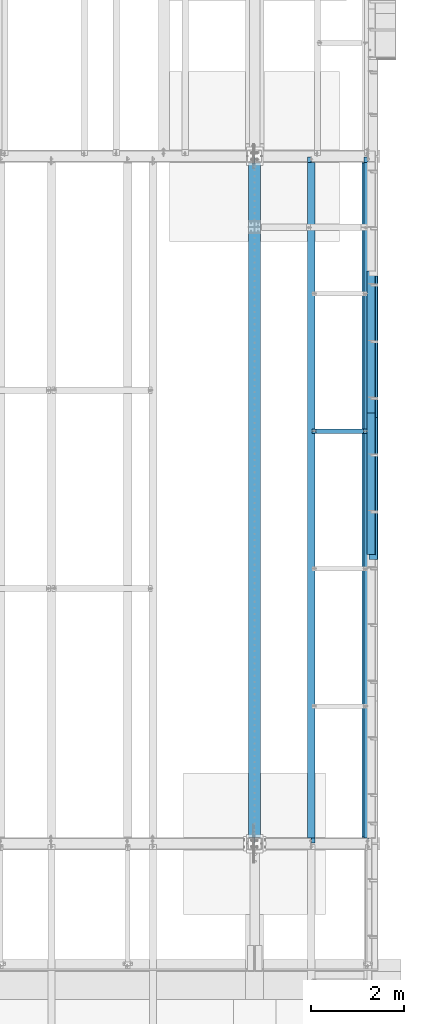
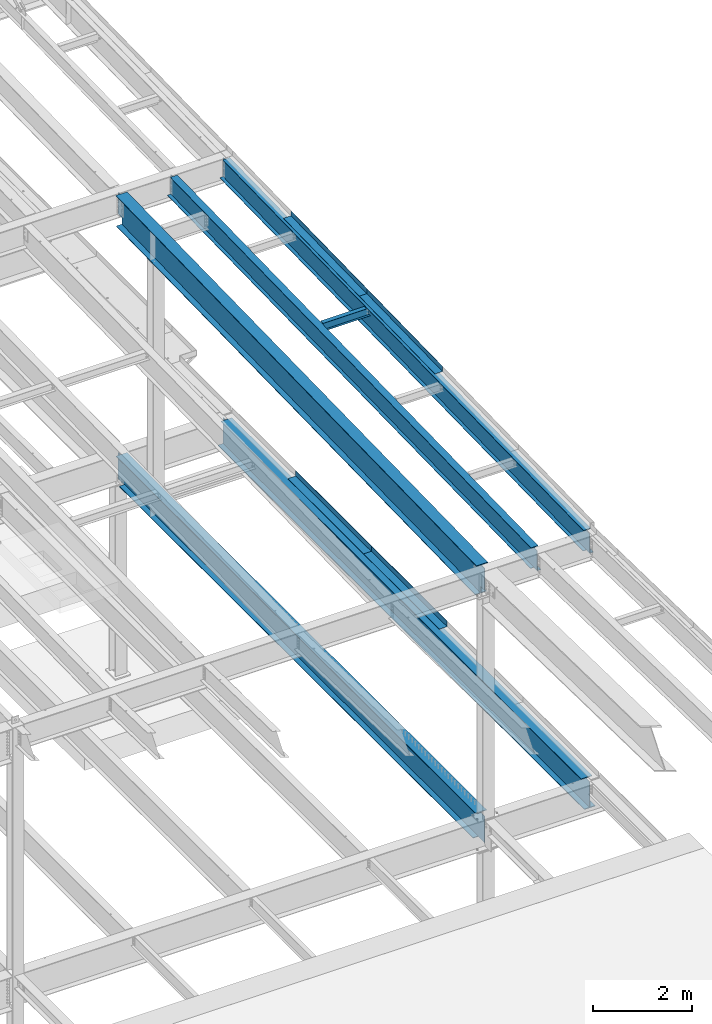
# One storey, part 1122 of 1763: 10 beams, 6 elements without a shape of their own.
"""IFC2X3 building model written with IfcOpenShell, lengths in millimetres."""

from ifc_helpers import new_model, si_unit, frame, origin_with_axes, place, context, subcontext, project, spatial, faceted_brep, material, type_object, element, aggregate, save


model = new_model("IFC2X3")

# Units and contexts
model_context = context("Model", 3, precision=1e-05, world=origin_with_axes())
body_context = subcontext(model_context, "Body", "Model", "MODEL_VIEW")
ifc_project = project(units=[si_unit("LENGTHUNIT", "METRE", prefix="MILLI"), si_unit("AREAUNIT", "SQUARE_METRE"), si_unit("VOLUMEUNIT", "CUBIC_METRE"), si_unit("MASSUNIT", "GRAM", prefix="KILO"), si_unit("TIMEUNIT", "SECOND"), si_unit("PLANEANGLEUNIT", "RADIAN"), si_unit("SOLIDANGLEUNIT", "STERADIAN"), si_unit("THERMODYNAMICTEMPERATUREUNIT", "DEGREE_CELSIUS"), si_unit("LUMINOUSINTENSITYUNIT", "LUMEN")], contexts=[model_context])

# Site, building, storey
site_placement = place(None, origin_with_axes())
site = spatial("IfcSite", under=ifc_project, at=site_placement, CompositionType="ELEMENT")
building_placement = place(site_placement, origin_with_axes())
building = spatial("IfcBuilding", under=site, at=building_placement, Name="Undefined", CompositionType="ELEMENT")
storey_placement = place(building_placement, origin_with_axes())
storey = spatial("IfcBuildingStorey", under=building, at=storey_placement, Name="Undefined", CompositionType="ELEMENT", Elevation=0.0)

# Assembly, beam
assembly_1_placement = place(storey_placement, origin_with_axes())
assembly_1 = element("IfcElementAssembly", 1, at=assembly_1_placement, inside=storey, Name="BEAM", AssemblyPlace="NOTDEFINED", PredefinedType="RIGID_FRAME")
ifc_material_1 = material(Name="STEEL/A992")
beam_type_1 = type_object("IfcBeamType", Name="W8X10", PredefinedType="NOTDEFINED")
beam_1_placement = place(assembly_1_placement, frame((-22808.6484080275, 38892.48, 11373.7981173788), z_axis=(0.0, 0.0, 1.0), x_axis=(1.0, 0.0, 0.0)))
beam_1 = element("IfcBeam", 2, at=beam_1_placement, type_object=beam_type_1, material=ifc_material_1, Name="BEAM", ObjectType="W8X10", context=body_context, shape_type="Brep", body=[
    faceted_brep([(1119.19526367187, -50.7999999999993, 100.012500000001), (1119.19526367187, -50.7999999999993, 95.25), (1119.19526367187, -2.38124999999854, 95.25), (1119.19526367187, -2.38124999999854, 83.877501483119), (1119.19526367187, 2.38124999999854, 83.877501483119), (1119.19526367187, 2.38124999999854, 95.25), (1119.19526367187, 50.7999999999993, 95.25), (1119.19526367187, 50.7999999999993, 100.012500000001), (1120.16199359446, -2.38124999999854, 79.0174219650726), (1120.16199359446, 2.38124999999854, 79.0174219650726), (1122.91500749494, -2.38124999999854, 74.8972454969189), (1122.91500749494, 2.38124999999854, 74.8972454969189), (1127.03518396309, -2.38124999999854, 72.1442315964414), (1127.03518396309, 2.38124999999854, 72.1442315964414), (1131.89526348114, -2.38124999999854, 71.1775016738538), (1131.89526348114, 2.38124999999854, 71.1775016738538), (1201.74526367187, -2.38124999999854, 71.1775016738538), (1201.74526367187, 2.38124999999854, 71.1775016738538), (100.012500000012, -50.7999999999993, 100.012500000001), (100.012500000012, 50.7999999999993, 100.012500000001), (100.012500000012, 50.7999999999993, 95.25), (100.012500000012, 2.38124999999854, 95.25), (100.012500000012, 2.38124999999854, 83.877501483119), (100.012500000012, -2.38124999999854, 83.877501483119), (100.012500000012, -2.38124999999854, 95.25), (100.012500000012, -50.7999999999993, 95.25), (99.0457700774241, 2.38124999999854, 79.0174219650726), (99.0457700774241, -2.38124999999854, 79.0174219650726), (96.2927561769466, 2.38124999999854, 74.8972454969189), (96.2927561769466, -2.38124999999854, 74.8972454969189), (92.1725797087929, 2.38124999999854, 72.1442315964414), (92.1725797087929, -2.38124999999854, 72.1442315964414), (87.3125001907465, 2.38124999999854, 71.1775016738538), (87.3125001907465, -2.38124999999854, 71.1775016738538), (17.4625000000015, 2.38124999999854, 71.1775016738538), (17.4625000000015, -2.38124999999854, 71.1775016738538), (17.462499935149, 2.38124999999854, -95.25), (17.4625000000015, 50.7999999999993, -95.25), (17.4625000000015, 50.7999999999993, -100.012500000001), (17.4624996160601, -50.8000000000029, -100.012500000001), (17.4624996160601, -50.8000000000029, -95.25), (17.4624999065727, -2.38124999999854, -95.25), (1201.74526367187, 2.38124999999854, -95.25), (1201.74526367187, 50.7999999999993, -95.25), (1201.74526367187, 50.7999999999993, -100.012500000001), (1201.74526367187, -50.7999999999993, -100.012500000001), (1201.74526367187, -50.7999999999993, -95.25), (1201.74526367187, -2.38124999999854, -95.25)], [[[0, 1, 2, 3, 4, 5, 6, 7]], [[8, 9, 4, 3]], [[10, 11, 9, 8]], [[12, 13, 11, 10]], [[14, 15, 13, 12]], [[16, 17, 15, 14]], [[18, 19, 20, 21, 22, 23, 24, 25]], [[23, 22, 26, 27]], [[27, 26, 28, 29]], [[29, 28, 30, 31]], [[31, 30, 32, 33]], [[33, 32, 34, 35]], [[36, 37, 38, 39, 40, 41, 35, 34]], [[37, 36, 42, 43]], [[38, 37, 43, 44]], [[39, 38, 44, 45]], [[40, 39, 45, 46]], [[41, 40, 46, 47]], [[12, 10, 8, 3, 2, 24, 23, 27, 29, 31, 33, 35, 41, 47, 16, 14]], [[25, 24, 2, 1]], [[18, 25, 1, 0]], [[19, 18, 0, 7]], [[20, 19, 7, 6]], [[21, 20, 6, 5]], [[42, 36, 34, 32, 30, 28, 26, 22, 21, 5, 4, 9, 11, 13, 15, 17]], [[47, 46, 45, 44, 43, 42, 17, 16]]]),
])
aggregate(assembly_1, [beam_1])

# Assembly, beams
assembly_2_placement = place(storey_placement, origin_with_axes())
assembly_2 = element("IfcElementAssembly", 3, at=assembly_2_placement, inside=storey, Name="BEAM", AssemblyPlace="NOTDEFINED", PredefinedType="RIGID_FRAME")
ifc_material_2 = material(Name="STEEL/A36")
beam_type_2 = type_object("IfcBeamType", PredefinedType="NOTDEFINED")
beam_2_placement = place(assembly_2_placement, frame((-21564.0372736984, 40709.85, 5199.0625), z_axis=(0.0, -1.0, 0.0), x_axis=(1.0, 0.0, 0.0)))
beam_2 = element("IfcBeam", 4, at=beam_2_placement, type_object=beam_type_2, material=ifc_material_2, Name="BENT_PLATE", context=body_context, shape_type="Brep", body=[
    faceted_brep([(0.0, -4.76249999999982, -1524.0), (0.0, -4.76249999999982, 1524.0), (0.0, 4.76249999999982, 1524.0), (0.0, 4.76249999999982, -1524.0), (177.799996948241, 4.76249999999982, 1524.0), (177.799996948241, 4.76249999999982, -1524.0), (187.324996948242, -4.76249999999982, -1524.0), (187.324996948242, -4.76249999999982, 1524.0), (177.799996948241, 134.937496948242, 1524.0), (177.799996948241, 134.937496948242, -1524.0), (187.324996948242, 134.937496948242, 1524.0), (187.324996948242, 134.937496948242, -1524.0)], [[[0, 1, 2, 3]], [[3, 2, 4, 5]], [[1, 0, 6, 7]], [[5, 4, 8, 9]], [[4, 2, 1, 7, 10, 8]], [[7, 6, 11, 10]], [[6, 0, 3, 5, 9, 11]], [[10, 11, 9, 8]]]),
])
beam_3_placement = place(assembly_2_placement, frame((-21564.0372736984, 37661.85, 5199.0625), z_axis=(0.0, -1.0, 0.0), x_axis=(1.0, 0.0, 0.0)))
beam_3 = element("IfcBeam", 5, at=beam_3_placement, type_object=beam_type_2, material=ifc_material_2, Name="BENT_PLATE", context=body_context, shape_type="Brep", body=[
    faceted_brep([(0.0, -4.76249999999982, -1524.0), (0.0, -4.76249999999982, 1524.0), (0.0, 4.76249999999982, 1524.0), (0.0, 4.76249999999982, -1524.0), (177.799996948241, 4.76249999999982, 1524.0), (177.799996948241, 4.76249999999982, -1524.0), (187.324996948242, -4.76249999999982, -1524.0), (187.324996948242, -4.76249999999982, 1524.0), (177.799996948241, 134.937496948242, 1524.0), (177.799996948241, 134.937496948242, -1524.0), (187.324996948242, 134.937496948242, 1524.0), (187.324996948242, 134.937496948242, -1524.0)], [[[0, 1, 2, 3]], [[3, 2, 4, 5]], [[1, 0, 6, 7]], [[5, 4, 8, 9]], [[4, 2, 1, 7, 10, 8]], [[7, 6, 11, 10]], [[6, 0, 3, 5, 9, 11]], [[10, 11, 9, 8]]]),
])

assembly_3_placement = place(storey_placement, origin_with_axes())
assembly_3 = element("IfcElementAssembly", 6, at=assembly_3_placement, inside=storey, Name="BEAM", AssemblyPlace="NOTDEFINED", PredefinedType="RIGID_FRAME")
beam_type_3 = type_object("IfcBeamType", PredefinedType="NOTDEFINED")
beam_4_placement = place(assembly_3_placement, frame((-21608.4906443556, 40810.1470958945, 11516.6621670875), z_axis=(0.0, -0.999786037781472, -0.0206852279954809), x_axis=(1.0, 0.0, 0.0)))
beam_4 = element("IfcBeam", 7, at=beam_4_placement, type_object=beam_type_3, material=ifc_material_2, Name="BENT_PLATE", context=body_context, shape_type="Brep", body=[
    faceted_brep([(0.0, -3.17499999999927, -1523.99999999999), (0.0, -3.17499999999927, 1524.0), (0.0, 3.17499999999927, 1524.0), (0.0, 3.17499999999927, -1523.99999999999), (174.625006103754, 3.17500000029031, 1523.99999999885), (174.625006103754, 3.17499999971005, -1523.99999999885), (180.975006103752, -3.17500000028485, -1523.99999999885), (180.975006103752, -3.17499999970642, 1523.99999999885), (174.625006103754, 123.824997298747, 1523.99999999882), (174.625006103754, 123.824997298168, -1523.99999999888), (180.975006103752, 123.824997298747, 1523.99999999882), (180.975006103752, 123.824997298168, -1523.99999999888)], [[[0, 1, 2, 3]], [[3, 2, 4, 5]], [[1, 0, 6, 7]], [[5, 4, 8, 9]], [[4, 2, 1, 7, 10, 8]], [[7, 6, 11, 10]], [[6, 0, 3, 5, 9, 11]], [[10, 11, 9, 8]]]),
])
beam_5_placement = place(assembly_3_placement, frame((-21608.4906443556, 37762.7992527388, 11453.6135921579), z_axis=(0.0, -0.999786037781472, -0.0206852279954809), x_axis=(1.0, 0.0, 0.0)))
beam_5 = element("IfcBeam", 8, at=beam_5_placement, type_object=beam_type_3, material=ifc_material_2, Name="BENT_PLATE", context=body_context, shape_type="Brep", body=[
    faceted_brep([(0.0, -3.17499999999927, -1523.99999999999), (0.0, -3.17499999999927, 1524.0), (0.0, 3.17499999999927, 1524.0), (0.0, 3.17499999999927, -1523.99999999999), (174.625006103754, 3.17500000029031, 1523.99999999885), (174.625006103754, 3.17499999971005, -1523.99999999885), (180.975006103752, -3.17500000028485, -1523.99999999885), (180.975006103752, -3.17499999970642, 1523.99999999885), (174.625006103754, 123.824997298747, 1523.99999999882), (174.625006103754, 123.824997298168, -1523.99999999888), (180.975006103752, 123.824997298747, 1523.99999999882), (180.975006103752, 123.824997298168, -1523.99999999888)], [[[0, 1, 2, 3]], [[3, 2, 4, 5]], [[1, 0, 6, 7]], [[5, 4, 8, 9]], [[4, 2, 1, 7, 10, 8]], [[7, 6, 11, 10]], [[6, 0, 3, 5, 9, 11]], [[10, 11, 9, 8]]]),
])

# Assembly, beam
assembly_4_placement = place(storey_placement, origin_with_axes())
assembly_4 = element("IfcElementAssembly", 9, at=assembly_4_placement, inside=storey, Name="BEAM", AssemblyPlace="NOTDEFINED", PredefinedType="RIGID_FRAME")
beam_type_4 = type_object("IfcBeamType", Name="W30X90", PredefinedType="NOTDEFINED")
beam_6_placement = place(assembly_4_placement, frame((-24027.8372736984, 30030.5497207982, 10915.7301609411), z_axis=(0.0, -0.0206852279954837, 0.999786037781472), x_axis=(0.0, 0.999786037781472, 0.0206852279954825)))
beam_6 = element("IfcBeam", 10, at=beam_6_placement, type_object=beam_type_4, material=ifc_material_1, Name="BEAM", ObjectType="W30X90", context=body_context, shape_type="Brep", body=[
    faceted_brep([(14640.7034803743, 131.762500000001, 358.774999996942), (14640.7034803743, 6.34999999999854, 358.774999996942), (129.757398656984, 6.34999999999854, 358.774999999707), (129.757398656984, 131.762500000001, 358.774999999707), (117.057398847737, -6.34999999999854, 330.199999999233), (117.057398847737, 6.34999999999854, 330.199999999233), (99.9081682041979, 6.34999999999854, 330.199999999239), (17.3405018432495, 6.34999999999854, 330.199999999255), (17.3405018432495, -6.34999999999854, 330.199999999255), (121.917478365773, -6.34999999999854, 331.166729921819), (121.917478365773, 6.34999999999854, 331.166729921819), (126.037654833919, -6.34999999999854, 333.919743822291), (126.037654833919, 6.34999999999854, 333.919743822291), (128.790668734389, -6.34999999999854, 338.039920290434), (128.790668734389, 6.34999999999854, 338.039920290434), (129.757398656981, -6.34999999999854, 342.899999808467), (129.757398656981, 6.34999999999854, 342.899999808467), (14640.7034803743, -131.762500000001, 374.649999996929), (14640.7034803743, 131.762500000001, 374.649999996929), (129.757398656984, 131.762500000001, 374.649999999694), (129.757398656984, -131.762500000001, 374.649999999694), (14640.7034803743, -131.762500000001, 358.774999996942), (129.757398656984, -131.762500000001, 358.774999999707), (14640.7034803743, -6.34999999999854, 358.774999996942), (129.757398656984, -6.34999999999854, 358.774999999707), (14640.7034803743, -6.34999999999854, 342.899999791671), (14640.7034803743, 6.34999999999854, 342.899999791671), (14641.6702102968, -6.34999999999854, 338.039920273635), (14641.6702102968, 6.34999999999854, 338.039920273635), (14644.4232241973, -6.34999999999854, 333.919743805487), (14644.4232241973, 6.34999999999854, 333.919743805487), (14648.5434006655, -6.34999999999854, 331.166729905017), (14648.5434006655, 6.34999999999854, 331.166729905017), (14653.4034801835, -6.34999999999854, 330.199999982429), (14653.4034801835, 6.34999999999854, 330.199999982429), (14766.7838252642, -6.34999999999854, 330.199999982409), (14766.7838252642, 6.34999999999854, 330.199999982409), (14755.879342702, -6.34999999999854, -196.850000016262), (14755.879342702, 6.34999999999854, -196.850000016262), (14615.303480183, -6.34999999999854, -196.850000016202), (14615.303480183, 6.34999999999854, -196.850000016202), (14610.4434006649, -6.34999999999854, -197.816729938788), (14610.4434006649, 6.34999999999854, -197.816729938788), (14606.3232241968, -6.34999999999854, -200.569743839258), (14606.3232241968, 6.34999999999854, -200.569743839258), (14603.5702102963, -6.34999999999854, -204.689920307403), (14603.5702102963, 6.34999999999854, -204.689920307403), (14602.6034803737, -6.34999999999854, -209.549999825436), (14602.6034803737, 6.34999999999854, -209.549999825436), (14602.6034803737, -6.34999999999854, -358.77500000251), (14602.6034803737, -131.762500000001, -358.77500000251), (14602.6034803736, -131.762500000001, -374.650000002497), (14602.6034803736, 131.762500000001, -374.650000002497), (14602.6034803737, 131.762500000001, -358.77500000251), (14602.6034803737, 6.34999999999854, -358.77500000251), (167.857398656637, -131.762500000001, -358.774999999761), (167.857398656637, -131.762500000001, -374.649999999749), (167.857398656637, 131.762500000001, -374.649999999749), (167.857398656637, 131.762500000001, -358.774999999761), (167.857398656637, 6.34999999999854, -358.774999999761), (164.137654833612, 6.34999999999854, -200.56974382248), (160.017478365473, 6.34999999999854, -197.816729922006), (155.157398847437, 6.34999999999854, -196.84999999942), (89.0036856419247, 6.34999999999854, -196.849999999406), (6.43601928097632, 6.34999999999854, -196.849999999389), (167.857398656666, 6.34999999999854, -209.549999808658), (166.890668734086, 6.34999999999854, -204.689920290622), (6.43601928097632, -6.34999999999854, -196.849999999389), (155.157398847437, -6.34999999999854, -196.84999999942), (160.017478365473, -6.34999999999854, -197.816729922006), (164.137654833612, -6.34999999999854, -200.56974382248), (166.890668734086, -6.34999999999854, -204.689920290622), (167.857398656666, -6.34999999999854, -209.549999808658), (167.857398656637, -6.34999999999854, -358.774999999761)], [[[0, 1, 2, 3]], [[4, 5, 6, 7, 8]], [[9, 10, 5, 4]], [[11, 12, 10, 9]], [[13, 14, 12, 11]], [[15, 16, 14, 13]], [[17, 18, 19, 20]], [[21, 17, 20, 22]], [[23, 21, 22, 24]], [[20, 19, 3, 2, 16, 15, 24, 22]], [[18, 0, 3, 19]], [[17, 21, 23, 25, 26, 1, 0, 18]], [[27, 28, 26, 25]], [[29, 30, 28, 27]], [[31, 32, 30, 29]], [[33, 34, 32, 31]], [[35, 36, 34, 33]], [[36, 35, 37, 38]], [[37, 39, 40, 38]], [[41, 42, 40, 39]], [[43, 44, 42, 41]], [[45, 46, 44, 43]], [[47, 48, 46, 45]], [[49, 50, 51, 52, 53, 54, 48, 47]], [[51, 50, 55, 56]], [[52, 51, 56, 57]], [[53, 52, 57, 58]], [[54, 53, 58, 59]], [[60, 61, 62, 63, 64, 7, 6, 5, 10, 12, 14, 16, 2, 1, 26, 28, 30, 32, 34, 36, 38, 40, 42, 44, 46, 48, 54, 59, 65, 66]], [[8, 7, 64, 67]], [[49, 47, 45, 43, 41, 39, 37, 35, 33, 31, 29, 27, 25, 23, 24, 15, 13, 11, 9, 4, 8, 67, 68, 69, 70, 71, 72, 73]], [[50, 49, 73, 55]], [[72, 65, 59, 58, 57, 56, 55, 73]], [[71, 66, 65, 72]], [[70, 60, 66, 71]], [[69, 61, 60, 70]], [[68, 62, 61, 69]], [[67, 64, 63, 62, 68]]]),
])
aggregate(assembly_4, [beam_6])

# Beam
beam_type_5 = type_object("IfcBeamType", Name="W21X44", PredefinedType="NOTDEFINED")
beam_7_placement = place(assembly_3_placement, frame((-21589.4406443556, 30028.2182369849, 11028.4185447245), z_axis=(0.0, -0.0206852279954837, 0.999786037781472), x_axis=(0.0, 0.999786037781472, 0.0206852279954825)))
beam_7 = element("IfcBeam", 11, at=beam_7_placement, type_object=beam_type_5, material=ifc_material_1, Name="BEAM", ObjectType="W21X44", context=body_context, shape_type="Brep", body=[
    faceted_brep([(139.840765958041, 5.0624053531028, -250.824999999837), (139.84076595803, 5.06258851904568, -261.937499999829), (7.42136414375636, 5.062579911988, -261.937499999804), (7.6512779327204, 5.06239676101177, -250.824999999812), (139.840760921616, 82.5499999999993, -250.824999999839), (139.840760921612, 82.5499999999993, -261.937499999829), (127.140760597267, -4.76250000000073, 236.277501487266), (127.140760597267, 4.76250000000073, 236.277501487266), (126.17403067468, 4.76250000000073, 231.417421969232), (126.17403067468, -4.76250000000073, 231.417421969232), (123.421016774206, 4.76250000000073, 227.297245501086), (123.421016774206, -4.76250000000073, 227.297245501086), (119.300840306059, 4.76250000000073, 224.544231600616), (119.300840306059, -4.76250000000073, 224.544231600616), (114.440760788024, 4.76250000000073, 223.57750167803), (114.440760788024, -4.76250000000073, 223.57750167803), (17.4665019286549, 4.76250000000073, 223.57750167805), (17.4665019286549, -4.76250000000073, 223.57750167805), (7.6512779327204, -4.76250000000073, -250.824999999812), (14757.094601354, -4.76250000000073, -250.825000002622), (14766.9098253491, -4.76250000000073, 223.5775016359), (14660.6840838038, -4.76250000000073, 223.577501635922), (14655.8240042858, -4.76250000000073, 224.544231558508), (14651.7038278176, -4.76250000000073, 227.29724545898), (14648.9508139171, -4.76250000000073, 231.417421927124), (14647.9840839945, -4.76250000000073, 236.27750144516), (14647.9840839945, -4.76250000000073, 250.824999997021), (127.140760597267, -4.76250000000073, 250.824999999786), (7.6512779327204, -82.5499999999993, -250.824999999812), (14635.2840833957, -82.5499999999993, -250.825000002598), (14635.2840740972, -5.06240535050893, -250.825000002598), (14757.094601354, -5.06239073285906, -250.825000002622), (7.42136414375636, -82.5499999999993, -261.937499999804), (14635.2840833957, -82.5499999999993, -261.93750000259), (14635.2840740973, -5.06258851835082, -261.93750000259), (14756.8646875651, -5.06257392829502, -261.937500002614), (14756.8646875651, 82.5499999999993, -261.937500002614), (14757.094601354, 82.5499999999993, -250.825000002622), (14757.094601354, 4.76250000000073, -250.825000002622), (14766.9098253491, 4.76250000000073, 223.5775016359), (14660.6840838038, 4.76250000000073, 223.577501635922), (14655.8240042858, 4.76250000000073, 224.544231558508), (14651.7038278176, 4.76250000000073, 227.29724545898), (14648.9508139171, 4.76250000000073, 231.417421927124), (14647.9840839945, 4.76250000000073, 236.27750144516), (14647.9840839945, -82.5499999999993, 261.937499997013), (14647.9840839945, -82.5499999999993, 250.824999997021), (14647.9840839945, 4.76250000000073, 250.824999997021), (14647.9840839945, 82.5499999999993, 250.824999997021), (14647.9840839945, 82.5499999999993, 261.937499997013), (127.140760597267, 4.76250000000073, 250.824999999786), (127.140760597267, 82.5499999999993, 250.824999999786), (127.140760597267, 82.5499999999993, 261.937499999778), (127.140760597267, -82.5499999999993, 261.937499999778), (127.140760597267, -82.5499999999993, 250.824999999786), (7.6512779327204, 4.76250000000073, -250.824999999812)], [[[0, 1, 2, 3]], [[4, 5, 1, 0]], [[6, 7, 8, 9]], [[9, 8, 10, 11]], [[11, 10, 12, 13]], [[13, 12, 14, 15]], [[15, 14, 16, 17]], [[9, 11, 13, 15, 17, 18, 19, 20, 21, 22, 23, 24, 25, 26, 27, 6]], [[19, 18, 28, 29, 30, 31]], [[28, 32, 33, 29]], [[29, 33, 34, 30]], [[31, 30, 34, 35]], [[36, 37, 38, 39, 20, 19, 31, 35]], [[20, 39, 40, 21]], [[21, 40, 41, 22]], [[22, 41, 42, 23]], [[23, 42, 43, 24]], [[24, 43, 44, 25]], [[45, 46, 26, 25, 44, 47, 48, 49]], [[48, 47, 50, 51]], [[49, 48, 51, 52]], [[45, 49, 52, 53]], [[46, 45, 53, 54]], [[26, 46, 54, 27]], [[53, 52, 51, 50, 7, 6, 27, 54]], [[47, 44, 43, 42, 41, 40, 39, 38, 55, 16, 14, 12, 10, 8, 7, 50]], [[32, 28, 18, 17, 16, 55, 3, 2]], [[36, 35, 34, 33, 32, 2, 1, 5]], [[37, 36, 5, 4]], [[55, 38, 37, 4, 0, 3]]]),
])

aggregate(assembly_3, [beam_4, beam_5, beam_7])

# Assembly, beam
assembly_5_placement = place(storey_placement, origin_with_axes())
assembly_5 = element("IfcElementAssembly", 12, at=assembly_5_placement, inside=storey, Name="BEAM", AssemblyPlace="NOTDEFINED", PredefinedType="RIGID_FRAME")
beam_8_placement = place(assembly_5_placement, frame((-22808.6484080275, 30028.2182369849, 11028.4185447245), z_axis=(0.0, -0.0206852279954837, 0.999786037781472), x_axis=(0.0, 0.999786037781472, 0.0206852279954825)))
beam_8 = element("IfcBeam", 13, at=beam_8_placement, type_object=beam_type_5, material=ifc_material_1, Name="BEAM", ObjectType="W21X44", context=body_context, shape_type="Brep", body=[
    faceted_brep([(139.840765958041, 5.0624053531028, -250.824999999837), (139.84076595803, 5.06258851904568, -261.937499999829), (7.42136414375636, 5.062579911988, -261.937499999804), (7.6512779327204, 5.06239676101177, -250.824999999812), (139.840760921616, 82.5499999999993, -250.824999999839), (139.840760921612, 82.5499999999993, -261.937499999829), (127.140760597267, -4.76250000000073, 236.277501487266), (127.140760597267, 4.76250000000073, 236.277501487266), (126.17403067468, 4.76250000000073, 231.417421969232), (126.17403067468, -4.76250000000073, 231.417421969232), (123.421016774206, 4.76250000000073, 227.297245501086), (123.421016774206, -4.76250000000073, 227.297245501086), (119.300840306059, 4.76250000000073, 224.544231600616), (119.300840306059, -4.76250000000073, 224.544231600616), (114.440760788024, 4.76250000000073, 223.57750167803), (114.440760788024, -4.76250000000073, 223.57750167803), (17.4665019286549, 4.76250000000073, 223.57750167805), (17.4665019286549, -4.76250000000073, 223.57750167805), (7.6512779327204, -4.76250000000073, -250.824999999812), (14757.094601354, -4.76250000000073, -250.825000002622), (14766.9098253491, -4.76250000000073, 223.5775016359), (14660.6840838038, -4.76250000000073, 223.577501635922), (14655.8240042858, -4.76250000000073, 224.544231558508), (14651.7038278176, -4.76250000000073, 227.29724545898), (14648.9508139171, -4.76250000000073, 231.417421927124), (14647.9840839945, -4.76250000000073, 236.27750144516), (14647.9840839945, -4.76250000000073, 250.824999997021), (127.140760597267, -4.76250000000073, 250.824999999786), (7.6512779327204, -82.5499999999993, -250.824999999812), (14635.2840833957, -82.5499999999993, -250.825000002598), (14635.2840740972, -5.06240535050893, -250.825000002598), (14757.094601354, -5.06239073285906, -250.825000002622), (7.42136414375636, -82.5499999999993, -261.937499999804), (14635.2840833957, -82.5499999999993, -261.93750000259), (14635.2840740973, -5.06258851835082, -261.93750000259), (14756.8646875651, -5.06257392829502, -261.937500002614), (14756.8646875651, 82.5499999999993, -261.937500002614), (14757.094601354, 82.5499999999993, -250.825000002622), (14757.094601354, 4.76250000000073, -250.825000002622), (14766.9098253491, 4.76250000000073, 223.5775016359), (14660.6840838038, 4.76250000000073, 223.577501635922), (14655.8240042858, 4.76250000000073, 224.544231558508), (14651.7038278176, 4.76250000000073, 227.29724545898), (14648.9508139171, 4.76250000000073, 231.417421927124), (14647.9840839945, 4.76250000000073, 236.27750144516), (14647.9840839945, -82.5499999999993, 261.937499997013), (14647.9840839945, -82.5499999999993, 250.824999997021), (14647.9840839945, 4.76250000000073, 250.824999997021), (14647.9840839945, 82.5499999999993, 250.824999997021), (14647.9840839945, 82.5499999999993, 261.937499997013), (127.140760597267, 4.76250000000073, 250.824999999786), (127.140760597267, 82.5499999999993, 250.824999999786), (127.140760597267, 82.5499999999993, 261.937499999778), (127.140760597267, -82.5499999999993, 261.937499999778), (127.140760597267, -82.5499999999993, 250.824999999786), (7.6512779327204, 4.76250000000073, -250.824999999812)], [[[0, 1, 2, 3]], [[4, 5, 1, 0]], [[6, 7, 8, 9]], [[9, 8, 10, 11]], [[11, 10, 12, 13]], [[13, 12, 14, 15]], [[15, 14, 16, 17]], [[9, 11, 13, 15, 17, 18, 19, 20, 21, 22, 23, 24, 25, 26, 27, 6]], [[19, 18, 28, 29, 30, 31]], [[28, 32, 33, 29]], [[29, 33, 34, 30]], [[31, 30, 34, 35]], [[36, 37, 38, 39, 20, 19, 31, 35]], [[20, 39, 40, 21]], [[21, 40, 41, 22]], [[22, 41, 42, 23]], [[23, 42, 43, 24]], [[24, 43, 44, 25]], [[45, 46, 26, 25, 44, 47, 48, 49]], [[48, 47, 50, 51]], [[49, 48, 51, 52]], [[45, 49, 52, 53]], [[46, 45, 53, 54]], [[26, 46, 54, 27]], [[53, 52, 51, 50, 7, 6, 27, 54]], [[47, 44, 43, 42, 41, 40, 39, 38, 55, 16, 14, 12, 10, 8, 7, 50]], [[32, 28, 18, 17, 16, 55, 3, 2]], [[36, 35, 34, 33, 32, 2, 1, 5]], [[37, 36, 5, 4]], [[55, 38, 37, 4, 0, 3]]]),
])
aggregate(assembly_5, [beam_8])

# Beam
beam_type_6 = type_object("IfcBeamType", Name="W27X84", PredefinedType="NOTDEFINED")
beam_9_placement = place(assembly_2_placement, frame((-21589.4372736984, 30022.8, 4854.575), z_axis=(0.0, 0.0, 1.0), x_axis=(0.0, 1.0, 0.0)))
beam_9 = element("IfcBeam", 14, at=beam_9_placement, type_object=beam_type_6, material=ifc_material_1, Name="BEAM", ObjectType="W27X84", context=body_context, shape_type="Brep", body=[
    faceted_brep([(14636.75, -127.0, 339.725), (14636.75, -127.0, 323.85), (14636.75, -5.55625000000146, 323.85), (14636.75, -5.55625000000146, 320.415001487731), (14636.75, 5.55625000000146, 320.415001487731), (14636.75, 5.55625000000146, 323.85), (14636.75, 127.0, 323.85), (14636.75, 127.0, 339.725), (14637.7167299226, -5.55625000000146, 315.554921969686), (14637.7167299226, 5.55625000000146, 315.554921969686), (14640.4697438231, -5.55625000000146, 311.434745501532), (14640.4697438231, 5.55625000000146, 311.434745501532), (14644.5899202912, -5.55625000000146, 308.681731601054), (14644.5899202912, 5.55625000000146, 308.681731601054), (14649.4499998093, -5.55625000000146, 307.715001678466), (14649.4499998093, 5.55625000000146, 307.715001678466), (14763.75, -5.55625000000146, 307.715001678466), (14763.75, 5.55625000000146, 307.715001678466), (146.050000000003, -127.0, 339.725), (146.050000000003, 127.0, 339.725), (146.050000000003, 127.0, 323.85), (146.050000000003, 5.55625000000146, 323.85), (146.050000000003, 5.55625000000146, 320.415001487731), (146.050000000003, -5.55625000000146, 320.415001487731), (146.050000000003, -5.55625000000146, 323.85), (146.050000000003, -127.0, 323.85), (145.083270077415, 5.55625000000146, 315.554921969686), (145.083270077415, -5.55625000000146, 315.554921969686), (142.330256176938, 5.55625000000146, 311.434745501532), (142.330256176938, -5.55625000000146, 311.434745501532), (138.210079708784, 5.55625000000146, 308.681731601054), (138.210079708784, -5.55625000000146, 308.681731601054), (133.350000190738, 5.55625000000146, 307.715001678466), (133.350000190738, -5.55625000000146, 307.715001678466), (19.0500000000029, 5.55625000000146, 307.715001678466), (19.0500000000029, -5.55625000000146, 307.715001678466), (19.0500000000029, 5.55625000000146, -323.85), (19.0500000000029, 127.0, -323.85), (19.0500000000029, 127.0, -339.725), (19.0500000000029, -127.0, -339.725), (19.0500000000029, -127.0, -323.85), (19.0500000000029, -5.55625000000146, -323.85), (14763.75, 5.55625000000146, -323.85), (14763.75, 127.0, -323.85), (14763.75, 127.0, -339.725), (14763.75, -127.0, -339.725), (14763.75, -127.0, -323.85), (14763.75, -5.55625000000146, -323.85)], [[[0, 1, 2, 3, 4, 5, 6, 7]], [[8, 9, 4, 3]], [[10, 11, 9, 8]], [[12, 13, 11, 10]], [[14, 15, 13, 12]], [[16, 17, 15, 14]], [[18, 19, 20, 21, 22, 23, 24, 25]], [[23, 22, 26, 27]], [[27, 26, 28, 29]], [[29, 28, 30, 31]], [[31, 30, 32, 33]], [[33, 32, 34, 35]], [[36, 37, 38, 39, 40, 41, 35, 34]], [[37, 36, 42, 43]], [[38, 37, 43, 44]], [[39, 38, 44, 45]], [[40, 39, 45, 46]], [[41, 40, 46, 47]], [[12, 10, 8, 3, 2, 24, 23, 27, 29, 31, 33, 35, 41, 47, 16, 14]], [[25, 24, 2, 1]], [[18, 25, 1, 0]], [[19, 18, 0, 7]], [[20, 19, 7, 6]], [[21, 20, 6, 5]], [[42, 36, 34, 32, 30, 28, 26, 22, 21, 5, 4, 9, 11, 13, 15, 17]], [[47, 46, 45, 44, 43, 42, 17, 16]]]),
])

aggregate(assembly_2, [beam_2, beam_3, beam_9])

# Assembly, beam
assembly_6_placement = place(storey_placement, origin_with_axes())
assembly_6 = element("IfcElementAssembly", 15, at=assembly_6_placement, inside=storey, Name="BEAM", AssemblyPlace="NOTDEFINED", PredefinedType="RIGID_FRAME")
beam_10_placement = place(assembly_6_placement, frame((-24027.8372736984, 30022.8, 4854.575), z_axis=(0.0, 0.0, 1.0), x_axis=(0.0, 1.0, 0.0)))
beam_10 = element("IfcBeam", 16, at=beam_10_placement, type_object=beam_type_6, material=ifc_material_1, Name="BEAM", ObjectType="W27X84", context=body_context, shape_type="Brep", body=[
    faceted_brep([(14509.7499930491, 5.55624709003678, -323.850000000061), (14509.7499930491, 5.55608411533831, -339.725), (14509.7499869769, 127.0, -339.725), (14509.7499869769, 127.0, -323.85), (14763.75, 5.55625000000146, -323.85), (14763.75, 5.55609681543865, -339.725), (14509.7499997489, -127.0, -323.85), (14509.7499936767, -5.55625000000146, -323.85), (273.050012336542, -5.55625000000146, -323.85), (273.050018408787, -127.0, -323.85), (171.450000000008, -5.55625000000146, 320.674999809265), (171.450000000008, 5.55625000000146, 320.674999809265), (170.48327007742, 5.55625000000146, 315.814920291219), (170.48327007742, -5.55625000000146, 315.814920291219), (167.730256176943, 5.55625000000146, 311.694743823065), (167.730256176943, -5.55625000000146, 311.694743823065), (163.610079708789, 5.55625000000146, 308.941729922587), (163.610079708789, -5.55625000000146, 308.941729922587), (158.750000190743, 5.55625000000146, 307.974999999999), (158.750000190743, -5.55625000000146, 307.974999999999), (19.0500000000029, 5.55625000000146, 307.974999999999), (19.0500000000029, -5.55625000000146, 307.974999999999), (273.050000251184, 127.0, -323.85), (273.050000251184, 127.0, -339.725), (273.050006323407, 5.55641901255876, -339.725), (273.050006323407, 5.55608398657932, -323.850000003504), (19.0500000000029, 5.55640631245842, -339.725), (19.0500000000029, 5.55625000000146, -323.85), (19.0500000000029, -5.55625000000146, -311.977797450343), (19.0500000000029, 5.55625000000146, -311.977562953608), (19.0500000000029, -5.5560968165737, -339.725), (19.0500000000029, -5.55625000000146, -323.85), (273.050012336542, -5.55608411647336, -339.725), (273.050018408787, -127.0, -339.725), (14509.7499997489, -127.0, -339.725), (14509.7499936767, -5.55641901255149, -339.725), (14763.75, -5.55625000000146, -323.85), (14763.75, -5.55640631245114, -339.725), (14763.75, -5.55625000000146, -311.977562953606), (14763.75, -5.55625000000146, 307.974999999999), (14649.4499998093, -5.55625000000146, 307.974999999999), (14644.5899202912, -5.55625000000146, 308.941729922587), (14640.4697438231, -5.55625000000146, 311.694743823065), (14637.7167299226, -5.55625000000146, 315.814920291219), (14636.75, -5.55625000000146, 320.674999809265), (14636.75, -5.55625000000146, 323.85), (171.450000000008, -5.55625000000146, 323.85), (14763.75, 5.55625000000146, 307.974999999999), (14649.4499998093, 5.55625000000146, 307.974999999999), (14644.5899202912, 5.55625000000146, 308.941729922587), (14640.4697438231, 5.55625000000146, 311.694743823065), (14637.7167299226, 5.55625000000146, 315.814920291219), (14636.75, 5.55625000000146, 320.674999809265), (14636.75, -127.0, 339.725), (14636.75, -127.0, 323.85), (14636.75, 5.55625000000146, 323.85), (14636.75, 127.0, 323.85), (14636.75, 127.0, 339.725), (171.450000000008, 5.55625000000146, 323.85), (171.450000000008, 127.0, 323.85), (171.450000000008, 127.0, 339.725), (171.450000000008, -127.0, 339.725), (171.450000000008, -127.0, 323.85), (14763.75, 5.55625000000146, -311.977797450139)], [[[0, 1, 2, 3]], [[4, 5, 1, 0]], [[6, 7, 8, 9]], [[10, 11, 12, 13]], [[13, 12, 14, 15]], [[15, 14, 16, 17]], [[17, 16, 18, 19]], [[19, 18, 20, 21]], [[22, 23, 24, 25]], [[25, 24, 26, 27]], [[28, 21, 20, 29, 27, 26, 30, 31]], [[31, 30, 32, 8]], [[9, 8, 32, 33]], [[34, 6, 9, 33]], [[6, 34, 35, 7]], [[36, 7, 35, 37]], [[13, 15, 17, 19, 21, 28, 31, 8, 7, 36, 38, 39, 40, 41, 42, 43, 44, 45, 46, 10]], [[39, 47, 48, 40]], [[40, 48, 49, 41]], [[41, 49, 50, 42]], [[42, 50, 51, 43]], [[43, 51, 52, 44]], [[53, 54, 45, 44, 52, 55, 56, 57]], [[56, 55, 58, 59]], [[57, 56, 59, 60]], [[53, 57, 60, 61]], [[54, 53, 61, 62]], [[45, 54, 62, 46]], [[61, 60, 59, 58, 11, 10, 46, 62]], [[55, 52, 51, 50, 49, 48, 47, 63, 4, 0, 25, 27, 29, 20, 18, 16, 14, 12, 11, 58]], [[22, 25, 0, 3]], [[23, 22, 3, 2]], [[37, 35, 34, 33, 32, 30, 26, 24, 23, 2, 1, 5]], [[63, 47, 39, 38, 36, 37, 5, 4]]]),
])
aggregate(assembly_6, [beam_10])

save(model, "model.ifc")
